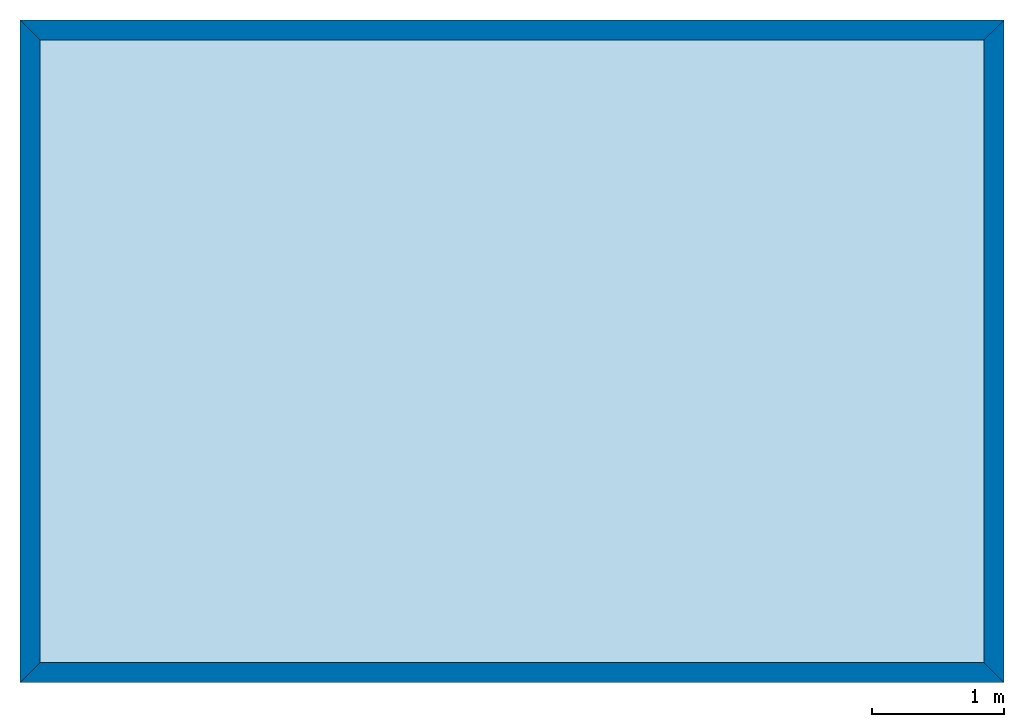
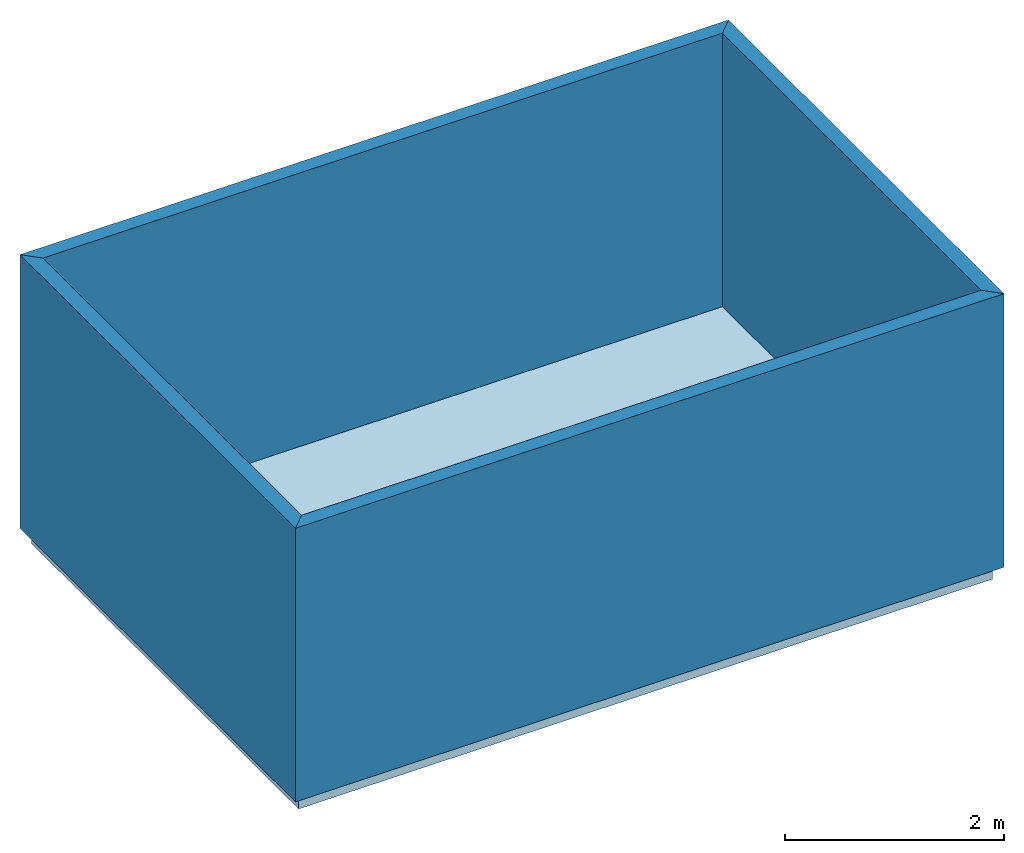
# One storey: 4 walls, 1 slab.
"""IFC4 building model written with IfcOpenShell, lengths in inches."""

from ifc_helpers import new_model, entity, si_unit, converted_unit, frame, origin, place, context, project, spatial, polyline, outline, extrude, material, layer, layer_set, layer_usage, element, save


model = new_model("IFC4")

# Units and contexts
model_context = context("Model", 3, precision=1e-05, world=origin())
plan_context = context("Plan", 2, precision=1e-05, world=origin())
ifc_project = project(units=[converted_unit("LENGTHUNIT", "inch", entity("IfcLengthMeasure", 0.0254), si_unit("LENGTHUNIT", "METRE"), dimensions=[1, 0, 0, 0, 0, 0, 0])], contexts=[model_context, plan_context])

# Site, building, storey
site_placement = place(None, origin())
site = spatial("IfcSite", under=ifc_project, at=site_placement, CompositionType="ELEMENT")
building_placement = place(site_placement, frame((576.0, 240.0, 48.0)))
building = spatial("IfcBuilding", under=site, at=building_placement, Name="Building #1", CompositionType="ELEMENT")
storey_placement = place(building_placement, origin())
storey = spatial("IfcBuildingStorey", under=building, at=storey_placement, Name="Ground Level", CompositionType="ELEMENT", Elevation=0.0)

# Slab
ifc_material = material(Name="Concrete (Nominal)", Category="Concrete")
ifc_layer = layer(ifc_material, 6.0, Name="Core")
ifc_layer_set = layer_set([ifc_layer])
ifc_layer_usage = layer_usage(ifc_layer_set, "AXIS3", "POSITIVE", 0.0)
slab_placement = place(storey_placement, origin())
element("IfcSlabStandardCase", 1, at=slab_placement, inside=storey, material=ifc_layer_usage, Name="Slab #1", PredefinedType="BASESLAB", context=model_context, shape_type="SweptSolid", body=[
    extrude(outline(polyline([(0.0, 0.0), (288.0, 0.0), (288.0, 192.0), (0.0, 192.0), (0.0, 0.0)])), origin(), (0.0, 0.0, 1.0), 6.0),
])

# Walls
wall_1_placement = place(storey_placement, frame((0.0, 0.0, 6.0), z_axis=(0.0, 0.0, 1.0), x_axis=(0.0, 1.0, 0.0)))
element("IfcWallStandardCase", 2, at=wall_1_placement, inside=storey, Name="Wall #1", PredefinedType="NOTDEFINED", context=model_context, shape_type="SweptSolid", body=[
    extrude(outline(polyline([(3.0, -3.0), (189.0, -3.0), (195.0, 3.0), (-3.0, 3.0), (3.0, -3.0)])), origin(), (0.0, 0.0, 1.0), 120.0),
])
wall_2_placement = place(storey_placement, frame((0.0, 192.0, 6.0), z_axis=(0.0, 0.0, 1.0), x_axis=(1.0, 0.0, 0.0)))
element("IfcWallStandardCase", 3, at=wall_2_placement, inside=storey, Name="Wall #2", PredefinedType="NOTDEFINED", context=model_context, shape_type="SweptSolid", body=[
    extrude(outline(polyline([(3.0, -3.0), (285.0, -3.0), (291.0, 3.0), (-3.0, 3.0), (3.0, -3.0)])), origin(), (0.0, 0.0, 1.0), 120.0),
])
wall_3_placement = place(storey_placement, frame((288.0, 192.0, 6.0), z_axis=(0.0, 0.0, 1.0), x_axis=(0.0, -1.0, 0.0)))
element("IfcWallStandardCase", 4, at=wall_3_placement, inside=storey, Name="Wall #3", PredefinedType="NOTDEFINED", context=model_context, shape_type="SweptSolid", body=[
    extrude(outline(polyline([(3.0, -3.0), (189.0, -3.0), (195.0, 3.0), (-3.0, 3.0), (3.0, -3.0)])), origin(), (0.0, 0.0, 1.0), 120.0),
])
wall_4_placement = place(storey_placement, frame((288.0, 0.0, 6.0), z_axis=(0.0, 0.0, 1.0), x_axis=(-1.0, 0.0, 0.0)))
element("IfcWallStandardCase", 5, at=wall_4_placement, inside=storey, Name="Wall #4", PredefinedType="NOTDEFINED", context=model_context, shape_type="SweptSolid", body=[
    extrude(outline(polyline([(3.0, -3.0), (285.0, -3.0), (291.0, 3.0), (-3.0, 3.0), (3.0, -3.0)])), origin(), (0.0, 0.0, 1.0), 120.0),
])

save(model, "model.ifc")
